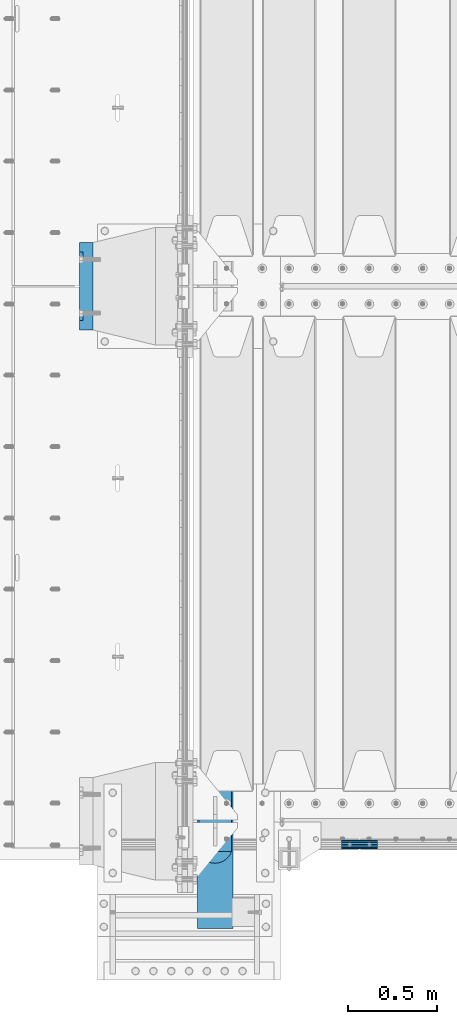
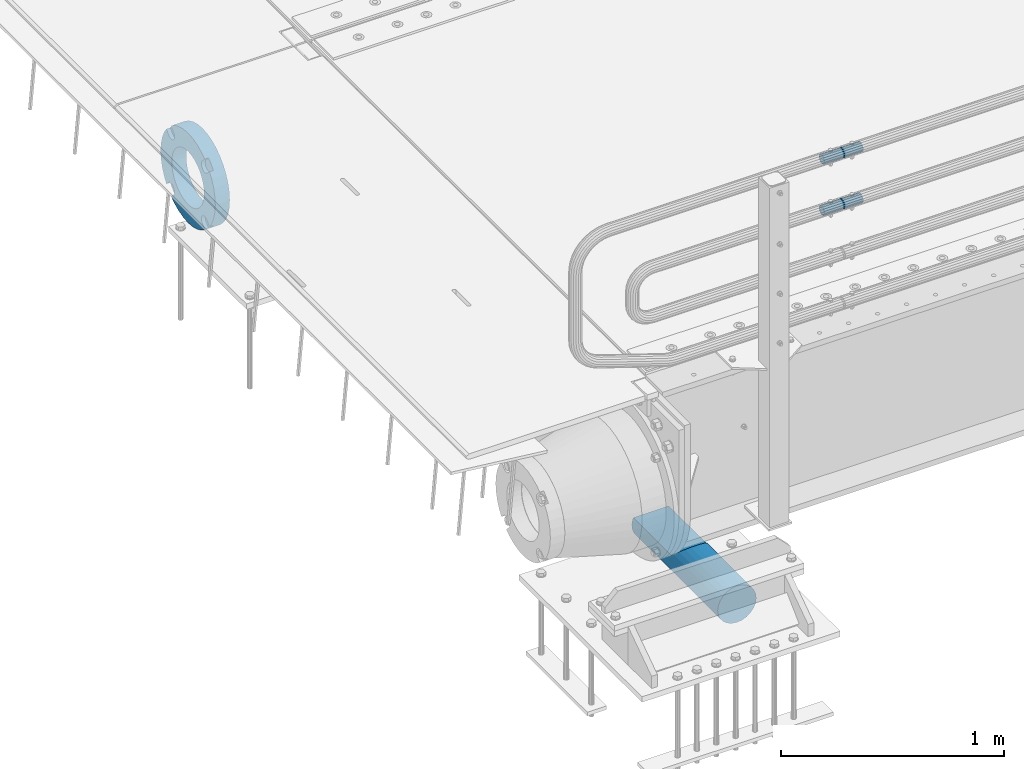
# One storey, part 138 of 247: 4 beams.
"""IFC2X3 building model written with IfcOpenShell, lengths in millimetres."""

from ifc_helpers import new_model, si_unit, frame, origin_with_axes, place, context, subcontext, project, spatial, faceted_brep, material, type_object, element, save


model = new_model("IFC2X3")

# Units and contexts
model_context = context("Model", 3, precision=1e-05, world=origin_with_axes())
body_context = subcontext(model_context, "Body", "Model", "MODEL_VIEW")
ifc_project = project(units=[si_unit("LENGTHUNIT", "METRE", prefix="MILLI"), si_unit("AREAUNIT", "SQUARE_METRE"), si_unit("VOLUMEUNIT", "CUBIC_METRE"), si_unit("MASSUNIT", "GRAM", prefix="KILO"), si_unit("TIMEUNIT", "SECOND"), si_unit("PLANEANGLEUNIT", "RADIAN"), si_unit("SOLIDANGLEUNIT", "STERADIAN"), si_unit("THERMODYNAMICTEMPERATUREUNIT", "DEGREE_CELSIUS"), si_unit("LUMINOUSINTENSITYUNIT", "LUMEN")], contexts=[model_context])

# Site, building, storey
site_placement = place(None, origin_with_axes())
site = spatial("IfcSite", under=ifc_project, at=site_placement, CompositionType="ELEMENT")
building_placement = place(site_placement, origin_with_axes())
building = spatial("IfcBuilding", under=site, at=building_placement, Name="Standard", CompositionType="ELEMENT")
storey_placement = place(building_placement, origin_with_axes())
storey = spatial("IfcBuildingStorey", under=building, at=storey_placement, Name="Undefined", CompositionType="ELEMENT", Elevation=0.0)

# Beams
ifc_material_1 = material(Name="STEEL/S355N")
beam_type_1 = type_object("IfcBeamType", Name="D200", PredefinedType="NOTDEFINED")
beam_1_placement = place(storey_placement, frame((135.0, -600.0, -928.0), z_axis=(0.0, 0.0, 1.0), x_axis=(0.0, 1.0, 0.0)))
element("IfcBeam", 1, at=beam_1_placement, inside=storey, type_object=beam_type_1, material=ifc_material_1, ObjectType="D200", context=body_context, shape_type="Brep", body=[
    faceted_brep([(417.294117647059, 86.6025403784438, 50.0), (395.365164344952, 70.7106781186548, 70.7106781186548), (378.538486658119, 50.0, 86.6025403784439), (367.960794863509, 25.8819045102521, 96.5925826289068), (364.35294117647, 0.0, 100.0), (367.960794863509, -25.8819045102521, 96.5925826289068), (378.538486658119, -50.0, 86.6025403784439), (395.365164344952, -70.7106781186548, 70.7106781186548), (417.294117647059, -86.6025403784439, 50.0), (430.0, -91.573103126921, 38.0), (430.0, 91.573103126921, 38.0), (770.0, -91.573103126921, 38.0), (770.0, 91.573103126921, 38.0), (0.0, -96.5925826289068, 25.8819045102521), (0.0, -86.6025403784439, 50.0), (0.0, -70.7106781186548, 70.7106781186548), (0.0, -50.0, 86.6025403784439), (0.0, -25.8819045102521, 96.5925826289068), (0.0, 0.0, 100.0), (0.0, 25.8819045102521, 96.5925826289068), (0.0, 50.0, 86.6025403784439), (0.0, 70.7106781186548, 70.7106781186548), (0.0, 86.6025403784438, 50.0), (0.0, 96.5925826289068, 25.8819045102521), (0.0, 100.0, 0.0), (0.0, 96.5925826289068, -25.8819045102521), (0.0, 86.6025403784439, -50.0), (0.0, 70.7106781186548, -70.7106781186548), (0.0, 50.0, -86.6025403784438), (0.0, 25.8819045102522, -96.5925826289067), (0.0, 2.8421709430404e-14, -100.0), (0.0, -25.881904510252, -96.5925826289069), (0.0, -49.9999999999999, -86.6025403784439), (0.0, -70.7106781186548, -70.7106781186548), (0.0, -86.6025403784438, -50.0), (0.0, -96.5925826289068, -25.8819045102522), (0.0, -100.0, 0.0), (770.0, 96.5925826289068, 25.8819045102521), (770.0, 100.0, 0.0), (770.0, 96.5925826289068, -25.8819045102521), (770.0, 86.6025403784439, -50.0), (770.0, 70.7106781186548, -70.7106781186548), (770.0, 50.0000000000001, -86.6025403784438), (770.0, 25.8819045102522, -96.5925826289067), (770.0, 2.8421709430404e-14, -100.0), (770.0, -25.881904510252, -96.5925826289069), (770.0, -49.9999999999999, -86.6025403784439), (770.0, -70.7106781186547, -70.7106781186548), (770.0, -86.6025403784438, -50.0), (770.0, -96.5925826289068, -25.8819045102522), (770.0, -100.0, 0.0), (770.0, -96.5925826289068, 25.8819045102521)], [[[0, 1, 2, 3, 4, 5, 6, 7, 8, 9, 10]], [[10, 9, 11, 12]], [[13, 14, 15, 16, 17, 18, 19, 20, 21, 22, 23, 24, 25, 26, 27, 28, 29, 30, 31, 32, 33, 34, 35, 36]], [[24, 23, 37, 38]], [[25, 24, 38, 39]], [[26, 25, 39, 40]], [[27, 26, 40, 41]], [[28, 27, 41, 42]], [[29, 28, 42, 43]], [[30, 29, 43, 44]], [[31, 30, 44, 45]], [[32, 31, 45, 46]], [[33, 32, 46, 47]], [[34, 33, 47, 48]], [[35, 34, 48, 49]], [[36, 35, 49, 50]], [[13, 36, 50, 51]], [[14, 13, 51, 11, 9, 8]], [[15, 14, 8, 7]], [[16, 15, 7, 6]], [[17, 16, 6, 5]], [[18, 17, 5, 4]], [[19, 18, 4, 3]], [[20, 19, 3, 2]], [[21, 20, 2, 1]], [[22, 21, 1, 0]], [[37, 23, 22, 0, 10, 12]], [[51, 50, 49, 48, 47, 46, 45, 44, 43, 42, 41, 40, 39, 38, 37, 12, 11]]]),
])
ifc_material_2 = material()
beam_type_2 = type_object("IfcBeamType", PredefinedType="NOTDEFINED")
beam_2_placement = place(storey_placement, frame((844.997502999948, -129.849999999603, 969.849999999725), z_axis=(0.0, 0.0, 1.0), x_axis=(1.0, 0.0, 0.0)))
element("IfcBeam", 2, at=beam_2_placement, inside=storey, type_object=beam_type_2, material=ifc_material_2, context=body_context, shape_type="Brep", body=[
    faceted_brep([(0.0, -21.8999999999996, 0.0), (0.0, -20.232961761998, 8.38076716879547), (200.0, -20.232961761998, 8.38076716879547), (200.0, -21.8999999999996, 0.0), (0.0, -15.4856385079856, 15.4856385079854), (200.0, -15.4856385079856, 15.4856385079854), (0.0, -8.3807671687955, 20.2329617619972), (200.0, -8.3807671687955, 20.2329617619972), (0.0, 0.0, 21.9), (200.0, 0.0, 21.9), (0.0, 8.3807671687955, 20.2329617619972), (200.0, 8.3807671687955, 20.2329617619972), (0.0, 15.4856385079856, 15.4856385079854), (200.0, 15.4856385079856, 15.4856385079854), (0.0, 20.232961761998, 8.38076716879547), (200.0, 20.232961761998, 8.38076716879547), (0.0, 21.8999999999996, 0.0), (200.0, 21.8999999999996, 0.0), (0.0, 20.232961761998, -8.38076716879547), (200.0, 20.232961761998, -8.38076716879547), (0.0, 15.4856385079856, -15.4856385079854), (200.0, 15.4856385079856, -15.4856385079854), (0.0, 8.3807671687955, -20.2329617619972), (200.0, 8.3807671687955, -20.2329617619972), (0.0, 0.0, -21.9), (200.0, 0.0, -21.9), (0.0, -8.3807671687955, -20.2329617619972), (200.0, -8.3807671687955, -20.2329617619972), (0.0, -15.4856385079856, -15.4856385079854), (200.0, -15.4856385079856, -15.4856385079854), (0.0, -20.232961761998, -8.38076716879547), (200.0, -20.232961761998, -8.38076716879547), (0.0, -25.5, 0.0), (0.0, -23.5589280790373, -9.7584275253098), (200.0, -23.5589280790373, -9.7584275253098), (200.0, -25.5, 0.0), (0.0, -18.0312229202573, -18.031222920257), (200.0, -18.0312229202573, -18.031222920257), (0.0, -9.75842752531025, -23.5589280790378), (200.0, -9.75842752531025, -23.5589280790378), (0.0, 0.0, -25.5), (200.0, 0.0, -25.5), (0.0, 9.75842752531025, -23.5589280790378), (200.0, 9.75842752531025, -23.5589280790378), (0.0, 18.0312229202573, -18.031222920257), (200.0, 18.0312229202573, -18.031222920257), (0.0, 23.5589280790373, -9.7584275253098), (200.0, 23.5589280790373, -9.7584275253098), (0.0, 25.5, 0.0), (200.0, 25.5, 0.0), (0.0, 23.5589280790373, 9.7584275253098), (200.0, 23.5589280790373, 9.7584275253098), (0.0, 18.0312229202573, 18.031222920257), (200.0, 18.0312229202573, 18.031222920257), (0.0, 9.75842752531025, 23.5589280790378), (200.0, 9.75842752531025, 23.5589280790378), (0.0, 0.0, 25.5), (200.0, 0.0, 25.5), (0.0, -9.75842752531025, 23.5589280790378), (200.0, -9.75842752531025, 23.5589280790378), (0.0, -18.0312229202573, 18.031222920257), (200.0, -18.0312229202573, 18.031222920257), (0.0, -23.5589280790373, 9.7584275253098), (200.0, -23.5589280790373, 9.7584275253098)], [[[0, 1, 2, 3]], [[1, 4, 5, 2]], [[4, 6, 7, 5]], [[6, 8, 9, 7]], [[8, 10, 11, 9]], [[10, 12, 13, 11]], [[12, 14, 15, 13]], [[14, 16, 17, 15]], [[16, 18, 19, 17]], [[18, 20, 21, 19]], [[20, 22, 23, 21]], [[22, 24, 25, 23]], [[24, 26, 27, 25]], [[26, 28, 29, 27]], [[28, 30, 31, 29]], [[30, 0, 3, 31]], [[32, 33, 34, 35]], [[33, 36, 37, 34]], [[36, 38, 39, 37]], [[38, 40, 41, 39]], [[40, 42, 43, 41]], [[42, 44, 45, 43]], [[44, 46, 47, 45]], [[46, 48, 49, 47]], [[48, 50, 51, 49]], [[50, 52, 53, 51]], [[52, 54, 55, 53]], [[54, 56, 57, 55]], [[56, 58, 59, 57]], [[58, 60, 61, 59]], [[60, 62, 63, 61]], [[62, 32, 35, 63]], [[37, 39, 41, 43, 45, 47, 49, 51, 53, 55, 57, 59, 61, 63, 35, 34], [5, 7, 9, 11, 13, 15, 17, 19, 21, 23, 25, 27, 29, 31, 3, 2]], [[62, 60, 58, 56, 54, 52, 50, 48, 46, 44, 42, 40, 38, 36, 33, 32], [30, 28, 26, 24, 22, 20, 18, 16, 14, 12, 10, 8, 6, 4, 1, 0]]]),
])
beam_3_placement = place(storey_placement, frame((844.997502999948, -129.849999999603, 689.849999999725), z_axis=(0.0, 0.0, 1.0), x_axis=(1.0, 0.0, 0.0)))
element("IfcBeam", 3, at=beam_3_placement, inside=storey, type_object=beam_type_2, material=ifc_material_2, context=body_context, shape_type="Brep", body=[
    faceted_brep([(0.0, -21.8999999999996, 0.0), (0.0, -20.232961761998, 8.38076716879547), (200.0, -20.232961761998, 8.38076716879547), (200.0, -21.8999999999996, 0.0), (0.0, -15.4856385079856, 15.4856385079854), (200.0, -15.4856385079856, 15.4856385079854), (0.0, -8.3807671687955, 20.2329617619972), (200.0, -8.3807671687955, 20.2329617619972), (0.0, 0.0, 21.9), (200.0, 0.0, 21.9), (0.0, 8.3807671687955, 20.2329617619972), (200.0, 8.3807671687955, 20.2329617619972), (0.0, 15.4856385079856, 15.4856385079854), (200.0, 15.4856385079856, 15.4856385079854), (0.0, 20.232961761998, 8.38076716879547), (200.0, 20.232961761998, 8.38076716879547), (0.0, 21.8999999999996, 0.0), (200.0, 21.8999999999996, 0.0), (0.0, 20.232961761998, -8.38076716879547), (200.0, 20.232961761998, -8.38076716879547), (0.0, 15.4856385079856, -15.4856385079854), (200.0, 15.4856385079856, -15.4856385079854), (0.0, 8.3807671687955, -20.2329617619972), (200.0, 8.3807671687955, -20.2329617619972), (0.0, 0.0, -21.9), (200.0, 0.0, -21.9), (0.0, -8.3807671687955, -20.2329617619972), (200.0, -8.3807671687955, -20.2329617619972), (0.0, -15.4856385079856, -15.4856385079854), (200.0, -15.4856385079856, -15.4856385079854), (0.0, -20.232961761998, -8.38076716879547), (200.0, -20.232961761998, -8.38076716879547), (0.0, -25.5, 0.0), (0.0, -23.5589280790373, -9.7584275253098), (200.0, -23.5589280790373, -9.7584275253098), (200.0, -25.5, 0.0), (0.0, -18.0312229202573, -18.031222920257), (200.0, -18.0312229202573, -18.031222920257), (0.0, -9.75842752531025, -23.5589280790378), (200.0, -9.75842752531025, -23.5589280790378), (0.0, 0.0, -25.5), (200.0, 0.0, -25.5), (0.0, 9.75842752531025, -23.5589280790378), (200.0, 9.75842752531025, -23.5589280790378), (0.0, 18.0312229202573, -18.031222920257), (200.0, 18.0312229202573, -18.031222920257), (0.0, 23.5589280790373, -9.7584275253098), (200.0, 23.5589280790373, -9.7584275253098), (0.0, 25.5, 0.0), (200.0, 25.5, 0.0), (0.0, 23.5589280790373, 9.7584275253098), (200.0, 23.5589280790373, 9.7584275253098), (0.0, 18.0312229202573, 18.031222920257), (200.0, 18.0312229202573, 18.031222920257), (0.0, 9.75842752531025, 23.5589280790378), (200.0, 9.75842752531025, 23.5589280790378), (0.0, 0.0, 25.5), (200.0, 0.0, 25.5), (0.0, -9.75842752531025, 23.5589280790378), (200.0, -9.75842752531025, 23.5589280790378), (0.0, -18.0312229202573, 18.031222920257), (200.0, -18.0312229202573, 18.031222920257), (0.0, -23.5589280790373, 9.7584275253098), (200.0, -23.5589280790373, 9.7584275253098)], [[[0, 1, 2, 3]], [[1, 4, 5, 2]], [[4, 6, 7, 5]], [[6, 8, 9, 7]], [[8, 10, 11, 9]], [[10, 12, 13, 11]], [[12, 14, 15, 13]], [[14, 16, 17, 15]], [[16, 18, 19, 17]], [[18, 20, 21, 19]], [[20, 22, 23, 21]], [[22, 24, 25, 23]], [[24, 26, 27, 25]], [[26, 28, 29, 27]], [[28, 30, 31, 29]], [[30, 0, 3, 31]], [[32, 33, 34, 35]], [[33, 36, 37, 34]], [[36, 38, 39, 37]], [[38, 40, 41, 39]], [[40, 42, 43, 41]], [[42, 44, 45, 43]], [[44, 46, 47, 45]], [[46, 48, 49, 47]], [[48, 50, 51, 49]], [[50, 52, 53, 51]], [[52, 54, 55, 53]], [[54, 56, 57, 55]], [[56, 58, 59, 57]], [[58, 60, 61, 59]], [[60, 62, 63, 61]], [[62, 32, 35, 63]], [[37, 39, 41, 43, 45, 47, 49, 51, 53, 55, 57, 59, 61, 63, 35, 34], [5, 7, 9, 11, 13, 15, 17, 19, 21, 23, 25, 27, 29, 31, 3, 2]], [[62, 60, 58, 56, 54, 52, 50, 48, 46, 44, 42, 40, 38, 36, 33, 32], [30, 28, 26, 24, 22, 20, 18, 16, 14, 12, 10, 8, 6, 4, 1, 0]]]),
])
ifc_material_3 = material(Name="SCN-500-E2")
beam_type_3 = type_object("IfcBeamType", PredefinedType="NOTDEFINED")
beam_4_placement = place(storey_placement, frame((-550.0, 3000.00000146624, -515.0), z_axis=(0.0, 0.0, 1.0), x_axis=(-1.0, 0.0, 0.0)))
element("IfcBeam", 4, at=beam_4_placement, inside=storey, type_object=beam_type_3, material=ifc_material_3, context=body_context, shape_type="Brep", body=[
    faceted_brep([(75.0, 192.717024793295, -150.290616455866), (75.0, 171.473395903973, -129.046987566544), (55.0000000000002, 171.473395903973, -129.046987566544), (55.0000000000002, 192.717024793295, -150.290616455866), (75.0, 167.467485558764, -125.68562967346), (55.0000000000002, 167.467485558764, -125.68562967346), (75.0, 162.938740320458, -123.070957391021), (55.0000000000002, 162.938740320458, -123.070957391021), (75.0, 158.024763821319, -121.282416213441), (55.0000000000002, 158.024763821319, -121.282416213441), (75.0, 152.874864750675, -120.374350059354), (55.0000000000002, 152.874864750675, -120.374350059354), (75.0, 147.645520185815, -120.374350059348), (55.0000000000002, 147.645520185815, -120.374350059348), (75.0, 142.495621115171, -121.282416213423), (55.0000000000002, 142.495621115171, -121.282416213423), (75.0, 137.581644616022, -123.070957390992), (55.0000000000002, 137.581644616022, -123.070957390992), (75.0, 133.052899377708, -125.68562967342), (55.0000000000002, 133.052899377708, -125.68562967342), (75.0, 129.04698903278, -129.046987566545), (55.0000000000002, 129.04698903278, -129.046987566545), (75.0, 125.685631139648, -133.052897911627), (55.0000000000002, 125.685631139648, -133.052897911627), (75.0, 123.070958857221, -137.581643149937), (55.0000000000002, 123.070958857221, -137.581643149937), (75.0, 121.282417679651, -142.495619649082), (55.0000000000002, 121.282417679651, -142.495619649082), (75.0, 120.374351525574, -147.64551871973), (55.0000000000002, 120.374351525574, -147.64551871973), (75.0, 120.374351525579, -152.874863284592), (55.0000000000002, 120.374351525579, -152.874863284592), (75.0, 121.282417679666, -158.024762355239), (55.0000000000002, 121.282417679666, -158.024762355239), (75.0, 123.070958857244, -162.938738854385), (55.0000000000002, 123.070958857244, -162.938738854385), (75.0, 125.68563113968, -167.467484092695), (55.0000000000002, 125.68563113968, -167.467484092695), (75.0, 129.04698903278, -171.473394437738), (55.0000000000002, 129.04698903278, -171.473394437738), (55.0000000000002, 150.290618180639, -192.717023585596), (75.0, 150.290618180639, -192.717023585596), (55.0000000000002, 157.482964373203, -187.68088856415), (55.0000000000002, 187.680888564149, -157.482964373202), (75.0, -192.717023585596, 150.290618180639), (75.0, -171.4733929715, 129.046987566544), (55.0000000000002, -171.4733929715, 129.046987566544), (55.0000000000002, -192.717023585596, 150.290618180639), (75.0, -167.467482626291, 125.685629673459), (55.0000000000002, -167.467482626291, 125.685629673459), (75.0, -162.938737387985, 123.070957391021), (55.0000000000002, -162.938737387985, 123.070957391021), (75.0, -158.024760888846, 121.28241621344), (55.0000000000002, -158.024760888846, 121.28241621344), (75.0, -152.874861818202, 120.374350059353), (55.0000000000002, -152.874861818202, 120.374350059353), (75.0, -147.645517253342, 120.374350059347), (55.0000000000002, -147.645517253342, 120.374350059347), (75.0, -142.495618182698, 121.282416213422), (55.0000000000002, -142.495618182698, 121.282416213422), (75.0, -137.58164168355, 123.070957390991), (55.0000000000002, -137.58164168355, 123.070957390991), (75.0, -133.052896445235, 125.685629673419), (55.0000000000002, -133.052896445235, 125.685629673419), (75.0, -129.046986100308, 129.046987566544), (55.0000000000002, -129.046986100308, 129.046987566544), (75.0, -125.685628207175, 133.052897911626), (55.0000000000002, -125.685628207175, 133.052897911626), (75.0, -123.070955924748, 137.581643149936), (55.0000000000002, -123.070955924748, 137.581643149936), (75.0, -121.282414747178, 142.495619649081), (55.0000000000002, -121.282414747178, 142.495619649081), (75.0, -120.374348593101, 147.645518719729), (55.0000000000002, -120.374348593101, 147.645518719729), (75.0, -120.374348593106, 152.874863284591), (55.0000000000002, -120.374348593106, 152.874863284591), (75.0, -121.282414747193, 158.024762355238), (55.0000000000002, -121.282414747193, 158.024762355238), (75.0, -123.070955924772, 162.938738854384), (55.0000000000002, -123.070955924772, 162.938738854384), (75.0, -125.685628207208, 167.467484092694), (55.0000000000002, -125.685628207208, 167.467484092694), (75.0, -129.046986100308, 171.473394437737), (55.0000000000002, -129.046986100308, 171.473394437737), (55.0000000000002, -150.290616455866, 192.717024793295), (75.0, -150.290616455866, 192.717024793295), (75.0, 150.290618180639, 192.717023585597), (75.0000000000001, 129.04698903278, 171.473394437739), (55.0000000000002, 129.04698903278, 171.473394437739), (55.0000000000002, 150.290618180637, 192.717023585597), (75.0000000000001, 125.685631139695, 167.46748409253), (55.0000000000002, 125.685631139695, 167.46748409253), (75.0000000000001, 123.070958857257, 162.938738854225), (55.0000000000002, 123.070958857257, 162.938738854225), (75.0000000000001, 121.282417679677, 158.024762355085), (55.0000000000002, 121.282417679677, 158.024762355085), (75.0000000000001, 120.37435152559, 152.874863284441), (55.0000000000002, 120.37435152559, 152.874863284441), (75.0000000000001, 120.374351525585, 147.645518719582), (55.0000000000002, 120.374351525585, 147.645518719582), (75.0000000000001, 121.282417679658, 142.495619648937), (55.0000000000002, 121.282417679658, 142.495619648937), (75.0000000000001, 123.070958857228, 137.581643149788), (55.0000000000002, 123.070958857228, 137.581643149788), (75.0000000000001, 125.685631139655, 133.052897911475), (55.0000000000002, 125.685631139655, 133.052897911475), (75.0000000000001, 129.04698903278, 129.046987566546), (55.0000000000002, 129.04698903278, 129.046987566546), (75.0000000000001, 133.052899377863, 125.685629673414), (55.0000000000002, 133.052899377863, 125.685629673414), (75.0000000000001, 137.581644616172, 123.070957390986), (55.0000000000002, 137.581644616172, 123.070957390986), (75.0000000000001, 142.495621115319, 121.282416213417), (55.0000000000002, 142.495621115319, 121.282416213417), (75.0000000000001, 147.645520185966, 120.37435005934), (55.0000000000002, 147.645520185966, 120.37435005934), (75.0000000000001, 152.874864750827, 120.374350059345), (55.0000000000002, 152.874864750827, 120.374350059345), (75.0000000000001, 158.024763821475, 121.282416213431), (55.0000000000002, 158.024763821475, 121.282416213431), (75.0000000000001, 162.93874032062, 123.07095739101), (55.0000000000002, 162.93874032062, 123.07095739101), (75.0000000000001, 167.467485558931, 125.685629673446), (55.0000000000002, 167.467485558931, 125.685629673446), (75.0000000000001, 171.473395903973, 129.046987566546), (55.0000000000002, 171.473395903973, 129.046987566546), (55.0000000000002, 192.717024793294, 150.290616455867), (75.0, 192.717024793294, 150.290616455867), (0.0, 212.176223927188, -122.5), (0.0, 230.224692092548, -83.7949351147888), (75.0, 230.224692092548, -83.7949351147888), (75.0, 212.176223927188, -122.5), (0.0, 241.277899487992, -42.5438035283978), (75.0, 241.277899487992, -42.5438035283978), (0.0, 245.0, 0.0), (75.0, 245.0, 0.0), (0.0, 241.277899487992, 42.543803528398), (75.0, 241.277899487992, 42.543803528398), (0.0, 230.224692092548, 83.7949351147889), (75.0, 230.224692092548, 83.7949351147889), (0.0, 212.176223927188, 122.5), (75.0, 212.176223927188, 122.5), (0.0, 187.680888564149, 157.482964373202), (55.0000000000002, 187.680888564149, 157.482964373202), (0.0, 157.482964373203, 187.68088856415), (55.0000000000002, 157.482964373203, 187.68088856415), (0.0, 122.5, 212.176223927187), (75.0, 122.5, 212.176223927187), (0.0, 83.794935114789, 230.224692092548), (75.0, 83.794935114789, 230.224692092548), (0.0, 42.5438035283987, 241.277899487991), (75.0, 42.5438035283987, 241.277899487991), (0.0, 0.0, 245.0), (75.0, 0.0, 245.0), (0.0, -42.5438035283987, 241.277899487991), (75.0, -42.5438035283987, 241.277899487991), (0.0, -83.794935114789, 230.224692092548), (75.0, -83.794935114789, 230.224692092548), (0.0, -122.5, 212.176223927187), (75.0, -122.5, 212.176223927187), (0.0, -157.482964373203, 187.68088856415), (55.0000000000002, -157.482964373203, 187.68088856415), (0.0, -187.680888564149, 157.482964373202), (55.0000000000002, -187.680888564149, 157.482964373202), (0.0, -212.176223927188, 122.5), (75.0, -212.176223927188, 122.5), (0.0, -230.224692092548, 83.7949351147888), (75.0, -230.224692092548, 83.7949351147888), (0.0, -241.277899487992, 42.5438035283979), (75.0, -241.277899487992, 42.5438035283979), (0.0, -245.0, 0.0), (75.0, -245.0, 0.0), (0.0, -187.680888564149, -157.482964373202), (0.0, -157.482964373203, -187.68088856415), (55.0000000000002, -157.482964373203, -187.68088856415), (55.0000000000002, -187.680888564149, -157.482964373202), (0.0, 83.794935114789, -230.224692092547), (0.0, 122.5, -212.176223927187), (75.0, 122.5, -212.176223927187), (75.0, 83.794935114789, -230.224692092547), (0.0, 42.5438035283987, -241.277899487991), (75.0, 42.5438035283987, -241.277899487991), (0.0, 0.0, -245.0), (75.0, 0.0, -245.0), (0.0, -42.5438035283987, -241.277899487991), (75.0, -42.5438035283987, -241.277899487991), (0.0, -83.794935114789, -230.224692092548), (75.0, -83.794935114789, -230.224692092548), (0.0, -122.5, -212.176223927187), (75.0, -122.5, -212.176223927187), (75.0, -150.290616455864, -192.717024793297), (55.0000000000002, -150.290616455864, -192.717024793296), (55.0000000000002, -129.046986100308, -171.47339443774), (55.0000000000002, -125.685628207224, -167.46748409253), (55.0000000000002, -123.070955924784, -162.938738854225), (55.0000000000002, -121.282414747204, -158.024762355085), (55.0000000000002, -120.374348593117, -152.874863284441), (55.0000000000002, -120.374348593112, -147.645518719582), (55.0000000000002, -121.282414747186, -142.495619648937), (55.0000000000002, -123.070955924755, -137.581643149788), (55.0000000000002, -125.685628207182, -133.052897911475), (55.0000000000002, -129.046986100308, -129.046987566547), (55.0000000000002, -133.05289644539, -125.685629673414), (55.0000000000002, -137.581641683699, -123.070957390986), (55.0000000000002, -142.495618182846, -121.282416213417), (55.0000000000002, -147.645517253493, -120.37435005934), (55.0000000000002, -152.874861818354, -120.374350059345), (55.0000000000002, -158.024760889002, -121.282416213431), (55.0000000000002, -162.938737388147, -123.07095739101), (55.0000000000002, -167.467482626458, -125.685629673446), (55.0000000000002, -171.4733929715, -129.046987566546), (55.0000000000002, -192.717023585594, -150.29061818064), (75.0, -129.046986100308, -171.47339443774), (75.0, -125.685628207224, -167.46748409253), (75.0, -123.070955924784, -162.938738854225), (75.0, -121.282414747204, -158.024762355085), (75.0, -120.374348593117, -152.874863284441), (75.0, -120.374348593112, -147.645518719582), (75.0, -121.282414747186, -142.495619648937), (75.0, -123.070955924755, -137.581643149788), (75.0, -125.685628207182, -133.052897911475), (75.0, -129.046986100308, -129.046987566547), (75.0, -133.05289644539, -125.685629673414), (75.0, -137.581641683699, -123.070957390986), (75.0, -142.495618182846, -121.282416213417), (75.0, -147.645517253493, -120.37435005934), (75.0, -152.874861818354, -120.374350059345), (75.0, -158.024760889002, -121.282416213431), (75.0, -162.938737388147, -123.07095739101), (75.0, -167.467482626458, -125.685629673446), (75.0, -171.4733929715, -129.046987566546), (75.0, -192.717023585596, -150.290618180641), (75.0, -212.176223927187, -122.5), (0.0, -212.176223927187, -122.5), (0.0, -230.224692092548, -83.794935114789), (75.0, -230.224692092548, -83.794935114789), (0.0, -241.277899487992, -42.5438035283979), (75.0, -241.277899487992, -42.5438035283979), (0.0, 187.680888564149, -157.482964373202), (0.0, 157.482964373203, -187.68088856415), (0.0, -142.797124186771, -25.1789857617049), (0.0, -136.255430013956, -49.592920782222), (0.0, -125.573683548744, -72.5), (0.0, -111.076444252252, -93.2042034045483), (0.0, -93.204203404548, -111.076444252252), (0.0, -72.5, -125.573683548744), (0.0, -49.5929207822228, -136.255430013957), (0.0, -25.1789857617041, -142.79712418677), (0.0, 0.0, -145.0), (0.0, 25.1789857617041, -142.79712418677), (0.0, 49.5929207822228, -136.255430013957), (0.0, 72.5, -125.573683548744), (0.0, 93.204203404548, -111.076444252252), (0.0, 111.076444252252, -93.2042034045483), (0.0, 125.573683548744, -72.5), (0.0, 136.255430013956, -49.592920782222), (0.0, 142.797124186771, -25.178985761705), (0.0, 145.0, 0.0), (0.0, 142.797124186771, 25.1789857617048), (0.0, 136.255430013956, 49.5929207822219), (0.0, 125.573683548744, 72.4999999999999), (0.0, 111.076444252252, 93.2042034045482), (0.0, 93.204203404548, 111.076444252252), (0.0, 72.5, 125.573683548744), (0.0, 49.5929207822228, 136.255430013957), (0.0, 25.1789857617041, 142.79712418677), (0.0, 0.0, 145.0), (0.0, -25.1789857617041, 142.79712418677), (0.0, -49.5929207822228, 136.255430013957), (0.0, -72.5, 125.573683548744), (0.0, -93.204203404548, 111.076444252252), (0.0, -111.076444252252, 93.2042034045483), (0.0, -125.573683548744, 72.5000000000001), (0.0, -136.255430013956, 49.5929207822221), (0.0, -142.797124186771, 25.1789857617049), (0.0, -145.0, 0.0), (75.0, -145.0, 0.0), (75.0, -142.797124186771, -25.1789857617049), (75.0, -136.255430013956, -49.592920782222), (75.0, -125.573683548744, -72.5), (75.0, -111.076444252252, -93.2042034045483), (75.0, -93.204203404548, -111.076444252252), (75.0, -72.5, -125.573683548744), (75.0, -49.5929207822228, -136.255430013957), (75.0, -25.1789857617041, -142.79712418677), (75.0, 0.0, -145.0), (75.0, 25.1789857617041, -142.79712418677), (75.0, 49.5929207822228, -136.255430013957), (75.0, 72.5, -125.573683548744), (75.0, 93.204203404548, -111.076444252252), (75.0, 111.076444252252, -93.2042034045483), (75.0, 125.573683548744, -72.5), (75.0, 136.255430013956, -49.592920782222), (75.0, 142.797124186771, -25.178985761705), (75.0, 145.0, 0.0), (75.0, 142.797124186771, 25.1789857617048), (75.0, 136.255430013956, 49.5929207822219), (75.0, 125.573683548744, 72.4999999999999), (75.0, 111.076444252252, 93.2042034045482), (75.0, 93.204203404548, 111.076444252252), (75.0, 72.5, 125.573683548744), (75.0, 49.5929207822228, 136.255430013957), (75.0, 25.1789857617041, 142.79712418677), (75.0, 0.0, 145.0), (75.0, -25.1789857617041, 142.79712418677), (75.0, -49.5929207822228, 136.255430013957), (75.0, -72.5, 125.573683548744), (75.0, -93.204203404548, 111.076444252252), (75.0, -111.076444252252, 93.2042034045483), (75.0, -125.573683548744, 72.5000000000001), (75.0, -136.255430013956, 49.5929207822221), (75.0, -142.797124186771, 25.1789857617049)], [[[0, 1, 2, 3]], [[4, 5, 2, 1]], [[6, 7, 5, 4]], [[8, 9, 7, 6]], [[10, 11, 9, 8]], [[12, 13, 11, 10]], [[14, 15, 13, 12]], [[16, 17, 15, 14]], [[18, 19, 17, 16]], [[20, 21, 19, 18]], [[22, 23, 21, 20]], [[24, 25, 23, 22]], [[26, 27, 25, 24]], [[28, 29, 27, 26]], [[30, 31, 29, 28]], [[32, 33, 31, 30]], [[34, 35, 33, 32]], [[36, 37, 35, 34]], [[38, 39, 37, 36]], [[40, 39, 38, 41]], [[42, 43, 3, 2, 5, 7, 9, 11, 13, 15, 17, 19, 21, 23, 25, 27, 29, 31, 33, 35, 37, 39, 40]], [[44, 45, 46, 47]], [[48, 49, 46, 45]], [[50, 51, 49, 48]], [[52, 53, 51, 50]], [[54, 55, 53, 52]], [[56, 57, 55, 54]], [[58, 59, 57, 56]], [[60, 61, 59, 58]], [[62, 63, 61, 60]], [[64, 65, 63, 62]], [[66, 67, 65, 64]], [[68, 69, 67, 66]], [[70, 71, 69, 68]], [[72, 73, 71, 70]], [[74, 75, 73, 72]], [[76, 77, 75, 74]], [[78, 79, 77, 76]], [[80, 81, 79, 78]], [[82, 83, 81, 80]], [[84, 83, 82, 85]], [[86, 87, 88, 89]], [[90, 91, 88, 87]], [[92, 93, 91, 90]], [[94, 95, 93, 92]], [[96, 97, 95, 94]], [[98, 99, 97, 96]], [[100, 101, 99, 98]], [[102, 103, 101, 100]], [[104, 105, 103, 102]], [[106, 107, 105, 104]], [[108, 109, 107, 106]], [[110, 111, 109, 108]], [[112, 113, 111, 110]], [[114, 115, 113, 112]], [[116, 117, 115, 114]], [[118, 119, 117, 116]], [[120, 121, 119, 118]], [[122, 123, 121, 120]], [[124, 125, 123, 122]], [[126, 125, 124, 127]], [[128, 129, 130, 131]], [[129, 132, 133, 130]], [[132, 134, 135, 133]], [[134, 136, 137, 135]], [[136, 138, 139, 137]], [[138, 140, 141, 139]], [[127, 141, 140, 142, 143, 126]], [[142, 144, 145, 143]], [[89, 88, 91, 93, 95, 97, 99, 101, 103, 105, 107, 109, 111, 113, 115, 117, 119, 121, 123, 125, 126, 143, 145]], [[144, 146, 147, 86, 89, 145]], [[146, 148, 149, 147]], [[148, 150, 151, 149]], [[150, 152, 153, 151]], [[152, 154, 155, 153]], [[154, 156, 157, 155]], [[156, 158, 159, 157]], [[85, 159, 158, 160, 161, 84]], [[160, 162, 163, 161]], [[47, 46, 49, 51, 53, 55, 57, 59, 61, 63, 65, 67, 69, 71, 73, 75, 77, 79, 81, 83, 84, 161, 163]], [[162, 164, 165, 44, 47, 163]], [[164, 166, 167, 165]], [[166, 168, 169, 167]], [[168, 170, 171, 169]], [[172, 173, 174, 175]], [[176, 177, 178, 179]], [[180, 176, 179, 181]], [[182, 180, 181, 183]], [[184, 182, 183, 185]], [[186, 184, 185, 187]], [[188, 186, 187, 189]], [[173, 188, 189, 190, 191, 174]], [[175, 174, 191, 192, 193, 194, 195, 196, 197, 198, 199, 200, 201, 202, 203, 204, 205, 206, 207, 208, 209, 210, 211]], [[190, 212, 192, 191]], [[213, 193, 192, 212]], [[214, 194, 193, 213]], [[215, 195, 194, 214]], [[216, 196, 195, 215]], [[217, 197, 196, 216]], [[218, 198, 197, 217]], [[219, 199, 198, 218]], [[220, 200, 199, 219]], [[221, 201, 200, 220]], [[222, 202, 201, 221]], [[223, 203, 202, 222]], [[224, 204, 203, 223]], [[225, 205, 204, 224]], [[226, 206, 205, 225]], [[227, 207, 206, 226]], [[228, 208, 207, 227]], [[229, 209, 208, 228]], [[230, 210, 209, 229]], [[211, 210, 230, 231]], [[232, 233, 172, 175, 211, 231]], [[234, 233, 232, 235]], [[236, 234, 235, 237]], [[170, 236, 237, 171]], [[168, 166, 164, 162, 160, 158, 156, 154, 152, 150, 148, 146, 144, 142, 140, 138, 136, 134, 132, 129, 128, 238, 239, 177, 176, 180, 182, 184, 186, 188, 173, 172, 233, 234, 236, 170], [240, 241, 242, 243, 244, 245, 246, 247, 248, 249, 250, 251, 252, 253, 254, 255, 256, 257, 258, 259, 260, 261, 262, 263, 264, 265, 266, 267, 268, 269, 270, 271, 272, 273, 274, 275]], [[240, 275, 276, 277]], [[241, 240, 277, 278]], [[242, 241, 278, 279]], [[243, 242, 279, 280]], [[244, 243, 280, 281]], [[245, 244, 281, 282]], [[246, 245, 282, 283]], [[247, 246, 283, 284]], [[248, 247, 284, 285]], [[249, 248, 285, 286]], [[250, 249, 286, 287]], [[251, 250, 287, 288]], [[252, 251, 288, 289]], [[253, 252, 289, 290]], [[254, 253, 290, 291]], [[255, 254, 291, 292]], [[256, 255, 292, 293]], [[257, 256, 293, 294]], [[258, 257, 294, 295]], [[259, 258, 295, 296]], [[260, 259, 296, 297]], [[261, 260, 297, 298]], [[262, 261, 298, 299]], [[263, 262, 299, 300]], [[264, 263, 300, 301]], [[265, 264, 301, 302]], [[266, 265, 302, 303]], [[267, 266, 303, 304]], [[268, 267, 304, 305]], [[269, 268, 305, 306]], [[270, 269, 306, 307]], [[271, 270, 307, 308]], [[272, 271, 308, 309]], [[273, 272, 309, 310]], [[274, 273, 310, 311]], [[275, 274, 311, 276]], [[24, 22, 20, 18, 16, 14, 12, 10, 8, 6, 4, 1, 0, 131, 130, 133, 135, 137, 139, 141, 127, 124, 122, 120, 118, 116, 114, 112, 110, 108, 106, 104, 102, 100, 98, 96, 94, 92, 90, 87, 86, 147, 149, 151, 153, 155, 157, 159, 85, 82, 80, 78, 76, 74, 72, 70, 68, 66, 64, 62, 60, 58, 56, 54, 52, 50, 48, 45, 44, 165, 167, 169, 171, 237, 235, 232, 231, 230, 229, 228, 227, 226, 225, 224, 223, 222, 221, 220, 219, 218, 217, 216, 215, 214, 213, 212, 190, 189, 187, 185, 183, 181, 179, 178, 41, 38, 36, 34, 32, 30, 28, 26], [310, 309, 308, 307, 306, 305, 304, 303, 302, 301, 300, 299, 298, 297, 296, 295, 294, 293, 292, 291, 290, 289, 288, 287, 286, 285, 284, 283, 282, 281, 280, 279, 278, 277, 276, 311]], [[238, 128, 131, 0, 3, 43]], [[239, 238, 43, 42]], [[178, 177, 239, 42, 40, 41]]]),
])

save(model, "model.ifc")
